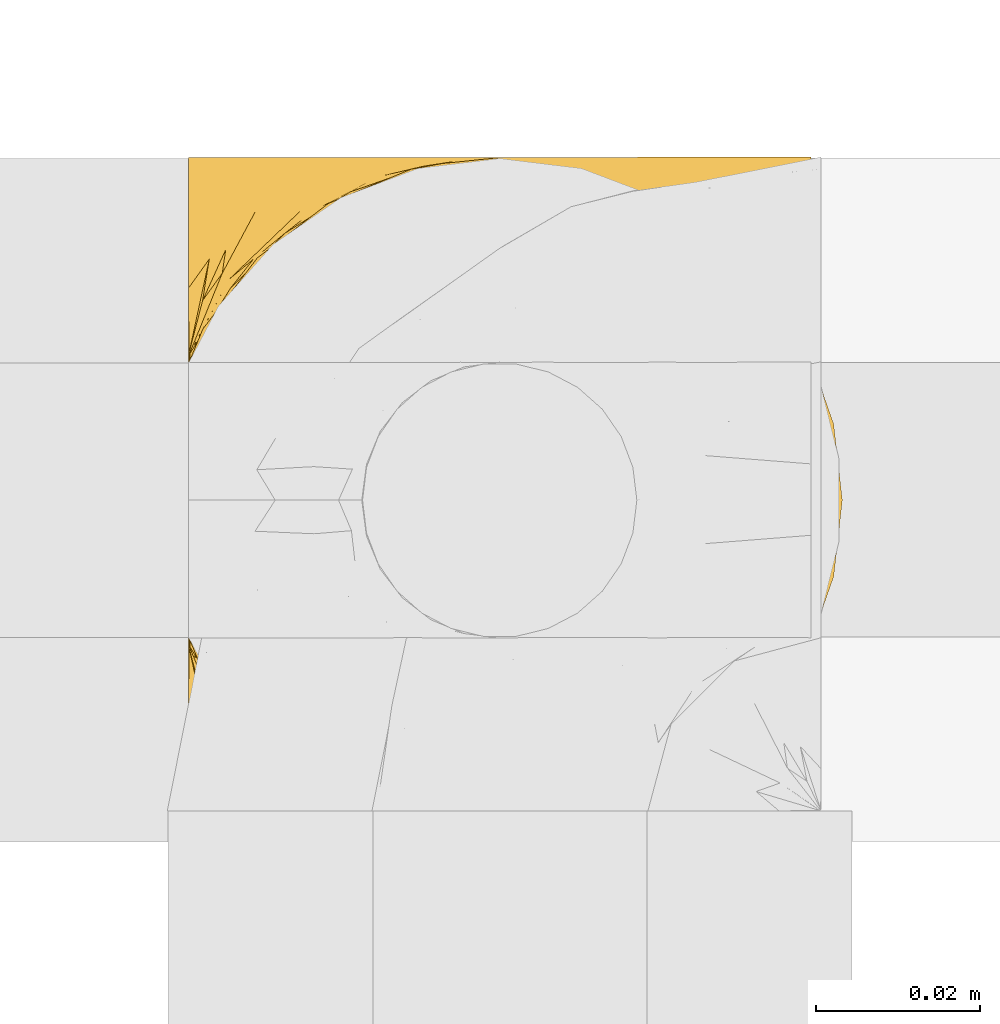
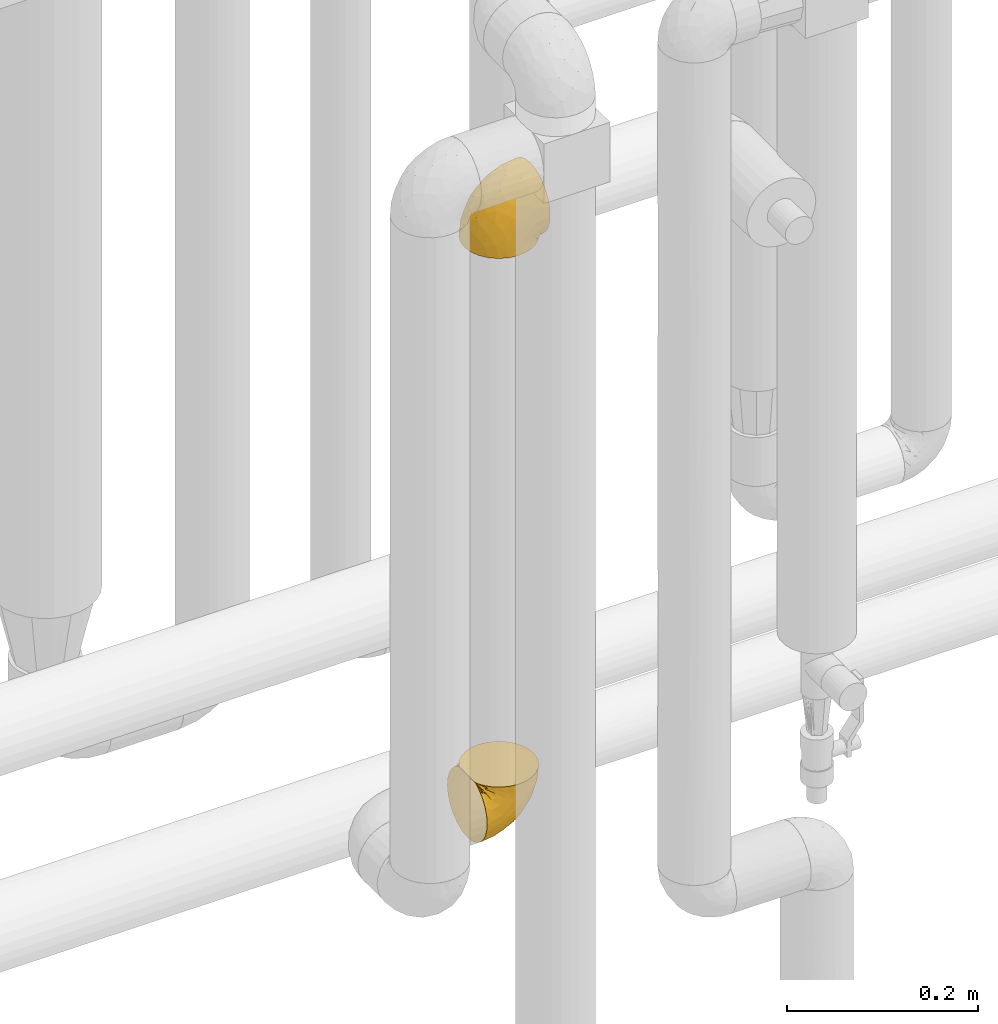
# One storey, part 446 of 827: 2 coverings.
"""IFC2X3 building model written with IfcOpenShell, lengths in millimetres."""

import ifcopenshell
import ifcopenshell.guid

model = None  # the IFC model being written
_history = None  # IfcOwnerHistory: only IFC2X3 demands one
_inside = {}  # id of a spatial element -> (the spatial element, [elements in it])
_under = {}  # id of a project, library or spatial element -> (it, [spatial elements below it])
_declared = {}  # id of a project -> (the project, [libraries it declares])
_typed = {}  # id of a type object -> (the type object, [elements of that type])
_made_of = {}  # id of a material, layer set ... -> (it, [elements and type objects made of it])


def new_model(schema):
    """Start an empty IFC model of exactly this schema.

    Asked for "IFC4X3", IfcOpenShell would pick the latest addendum, in which some entities
    have other attributes; the version numbers below select the first issue.
    IFC2X3 requires an IfcOwnerHistory on every rooted entity: one is made here for all.
    """
    global model, _history
    if schema == "IFC4X3":
        model = ifcopenshell.file(schema_version=(4, 3, 0, 0))
    else:
        model = ifcopenshell.file(schema=schema)
    _inside.clear()
    _under.clear()
    _declared.clear()
    _typed.clear()
    _made_of.clear()
    _history = None
    if model.schema == "IFC2X3":
        org = make("IfcOrganization", Name="unknown")
        user = make(
            "IfcPersonAndOrganization",
            ThePerson=make("IfcPerson", FamilyName="unknown"),
            TheOrganization=org,
        )
        app = make(
            "IfcApplication",
            ApplicationDeveloper=org,
            Version="unknown",
            ApplicationFullName="unknown",
            ApplicationIdentifier="unknown",
        )
        _history = make(
            "IfcOwnerHistory",
            OwningUser=user,
            OwningApplication=app,
            ChangeAction="ADDED",
            CreationDate=0,
        )
    return model


def make(cls, **values):
    """One entity of the class cls with the attributes given. An attribute that is None is left unset."""
    return model.create_entity(
        cls, **{name: value for name, value in values.items() if value is not None}
    )


def entity(cls, *values):
    """Any entity or typed value of the class cls, its attributes in the order of the schema. None: left unset."""
    e = model.create_entity(cls)
    for i, value in enumerate(values):
        if value is not None:
            e[i] = value
    return e


def rooted(cls, **values):
    """An entity with a GlobalId (a new one), such as an element, a storey or a relation."""
    return make(cls, GlobalId=ifcopenshell.guid.new(), OwnerHistory=_history, **values)


def si_unit(unit_type, name, prefix=None):
    """IfcSIUnit, for example si_unit("LENGTHUNIT", "METRE", prefix="MILLI")."""
    return make("IfcSIUnit", UnitType=unit_type, Prefix=prefix, Name=name)


def converted_unit(unit_type, name, factor, base, dimensions=None, offset=None):
    """IfcConversionBasedUnit, such as the inch: factor (a typed value) times the base unit."""
    return make(
        "IfcConversionBasedUnit"
        if offset is None
        else "IfcConversionBasedUnitWithOffset",
        ConversionOffset=offset,
        Dimensions=None
        if dimensions is None
        else entity("IfcDimensionalExponents", *dimensions),
        UnitType=unit_type,
        Name=name,
        ConversionFactor=make(
            "IfcMeasureWithUnit", ValueComponent=factor, UnitComponent=base
        ),
    )


def derived_unit(unit_type, elements):
    """IfcDerivedUnit: a product of units, each with its exponent."""
    return make(
        "IfcDerivedUnit",
        Elements=[
            make("IfcDerivedUnitElement", Unit=unit, Exponent=power)
            for unit, power in elements
        ],
        UnitType=unit_type,
    )


def assignment(units):
    """IfcUnitAssignment: the units of a project."""
    return None if units is None else make("IfcUnitAssignment", Units=units)


def point(xyz):
    """IfcCartesianPoint."""
    return None if xyz is None else make("IfcCartesianPoint", Coordinates=xyz)


def direction(xyz):
    """IfcDirection."""
    return None if xyz is None else make("IfcDirection", DirectionRatios=xyz)


def frame(location, z_axis=None, x_axis=None):
    """IfcAxis2Placement3D, a coordinate frame: its origin and axes. An axis left out is left unset."""
    return make(
        "IfcAxis2Placement3D",
        Location=point(location),
        Axis=direction(z_axis),
        RefDirection=direction(x_axis),
    )


def origin():
    """The frame at (0, 0, 0) with its axes left unset."""
    return frame((0.0, 0.0, 0.0))


def place(relative_to, where):
    """IfcLocalPlacement: puts the frame where relative to a parent placement (None: the world)."""
    return make(
        "IfcLocalPlacement", PlacementRelTo=relative_to, RelativePlacement=where
    )


def context(
    kind, dimensions, precision=None, world=None, true_north=None, identifier=None
):
    """IfcGeometricRepresentationContext, for example the 3D "Model" context."""
    return make(
        "IfcGeometricRepresentationContext",
        ContextIdentifier=identifier,
        ContextType=kind,
        CoordinateSpaceDimension=dimensions,
        Precision=precision,
        WorldCoordinateSystem=world,
        TrueNorth=true_north,
    )


def subcontext(parent, identifier, kind, view, scale=None):
    """IfcGeometricRepresentationSubContext, for example "Body" below "Model"."""
    return make(
        "IfcGeometricRepresentationSubContext",
        ContextIdentifier=identifier,
        ContextType=kind,
        ParentContext=parent,
        TargetScale=scale,
        TargetView=view,
    )


def project(units=None, contexts=None):
    """IfcProject with its units and contexts."""
    return rooted(
        "IfcProject",
        Name="project",
        RepresentationContexts=contexts,
        UnitsInContext=assignment(units),
    )


def spatial(cls, under=None, at=None, **own):
    """A site, building, storey or space (cls), placed at a placement, below another one or the project."""
    s = rooted(cls, ObjectPlacement=at, **own)
    if under is not None:
        _under.setdefault(under.id(), (under, []))[1].append(s)
    return s


def faces_of(points, faces, orient=None, outer=None):
    """IfcFace entities. A face is a list of loops; a loop is a list of indices into points, from 0.

    orient and outer hold one flag for each loop. By default every Orientation is true, the
    first loop of a face is its IfcFaceOuterBound and the others are IfcFaceBound.
    """
    made = []
    for i, loops in enumerate(faces):
        bounds = []
        for j, loop in enumerate(loops):
            is_outer = j == 0 if outer is None else outer[i][j]
            bounds.append(
                make(
                    "IfcFaceOuterBound" if is_outer else "IfcFaceBound",
                    Bound=make("IfcPolyLoop", Polygon=[points[k] for k in loop]),
                    Orientation=True if orient is None else orient[i][j],
                )
            )
        made.append(make("IfcFace", Bounds=bounds))
    return made


def faceted_brep(points, faces, orient=None, outer=None, voids=None):
    """IfcFacetedBrep: a solid bounded by flat faces; with voids (closed shells), ...WithVoids."""
    shared = [point(p) for p in points]
    hull = make("IfcClosedShell", CfsFaces=faces_of(shared, faces, orient, outer))
    if voids is None:
        return make("IfcFacetedBrep", Outer=hull)
    return make(
        "IfcFacetedBrepWithVoids",
        Outer=hull,
        Voids=[
            make(cls, CfsFaces=faces_of(shared, fs, o, b)) for cls, fs, o, b in voids
        ],
    )


def shape(context_of_items, identifier, shape_type, items):
    """IfcShapeRepresentation: the items that make up one representation, for example the "Body"."""
    return make(
        "IfcShapeRepresentation",
        ContextOfItems=context_of_items,
        RepresentationIdentifier=identifier,
        RepresentationType=shape_type,
        Items=items,
    )


def made_of(thing, what):
    """Note that an element or type object is made of a material, layer set ...; save() writes the relation."""
    if what is not None:
        _made_of.setdefault(what.id(), (what, []))[1].append(thing)
    return thing


def element(
    cls,
    number,
    at=None,
    inside=None,
    cuts=None,
    type_object=None,
    material=None,
    context=None,
    identifier="Body",
    shape_type=None,
    held_by="IfcProductDefinitionShape",
    body=None,
    shapes=None,
    **own,
):
    """One element of the class cls, such as IfcWall. Its Tag is "e" and its number.

    at: its placement. inside: the storey or other place that contains it. cuts: it is an
    opening in that element (IfcRelVoidsElement). A single representation is given by context,
    identifier, shape_type and body (its items); several are given by shapes. held_by: the class
    of the entity that holds the representations. save() writes the other relations.
    """
    e = rooted(cls, Tag="e%d" % number, ObjectPlacement=at, **own)
    if body is not None:
        shapes = [shape(context, identifier, shape_type, body)]
    if shapes is not None:
        e.Representation = make(held_by, Representations=shapes)
    if inside is not None:
        _inside.setdefault(inside.id(), (inside, []))[1].append(e)
    if cuts is not None:
        rooted(
            "IfcRelVoidsElement", RelatingBuildingElement=cuts, RelatedOpeningElement=e
        )
    if type_object is not None:
        _typed.setdefault(type_object.id(), (type_object, []))[1].append(e)
    return made_of(e, material)


def aggregate(whole, parts):
    """IfcRelAggregates: a whole, such as a stair, and the parts it consists of."""
    return rooted("IfcRelAggregates", RelatingObject=whole, RelatedObjects=parts)


def save(model, path):
    """Write the relations noted so far, then the file.

    IfcRelAggregates (storeys below a building ...), IfcRelContainedInSpatialStructure (elements
    in a storey), IfcRelDefinesByType, IfcRelAssociatesMaterial and IfcRelDeclares: one each for
    every whole, place, type object, material and project.
    """
    for whole, parts in _under.values():
        aggregate(whole, parts)
    for where, things in _inside.values():
        rooted(
            "IfcRelContainedInSpatialStructure",
            RelatedElements=things,
            RelatingStructure=where,
        )
    for kind, things in _typed.values():
        rooted("IfcRelDefinesByType", RelatedObjects=things, RelatingType=kind)
    for what, things in _made_of.values():
        rooted("IfcRelAssociatesMaterial", RelatedObjects=things, RelatingMaterial=what)
    for by, libraries in _declared.values():
        rooted("IfcRelDeclares", RelatingContext=by, RelatedDefinitions=libraries)
    model.write(path)


model = new_model("IFC2X3")

# Units and contexts
model_context = context("Model", 3, precision=0.01, world=origin(), true_north=direction((6.12303176911189e-17, 1.0)))
body_context = subcontext(model_context, "Body", "Model", "MODEL_VIEW")
ifc_project = project(units=[si_unit("LENGTHUNIT", "METRE", prefix="MILLI"), si_unit("AREAUNIT", "SQUARE_METRE"), si_unit("VOLUMEUNIT", "CUBIC_METRE"), converted_unit("PLANEANGLEUNIT", "DEGREE", entity("IfcRatioMeasure", 0.0174532925199433), si_unit("PLANEANGLEUNIT", "RADIAN"), dimensions=[0, 0, 0, 0, 0, 0, 0]), si_unit("MASSUNIT", "GRAM", prefix="KILO"), derived_unit("MASSDENSITYUNIT", [(si_unit("MASSUNIT", "GRAM", prefix="KILO"), 1), (si_unit("LENGTHUNIT", "METRE"), -3)]), derived_unit("MOMENTOFINERTIAUNIT", [(si_unit("LENGTHUNIT", "METRE"), 4)]), si_unit("TIMEUNIT", "SECOND"), si_unit("FREQUENCYUNIT", "HERTZ"), si_unit("THERMODYNAMICTEMPERATUREUNIT", "DEGREE_CELSIUS"), derived_unit("THERMALTRANSMITTANCEUNIT", [(si_unit("MASSUNIT", "GRAM", prefix="KILO"), 1), (si_unit("THERMODYNAMICTEMPERATUREUNIT", "KELVIN"), -1), (si_unit("TIMEUNIT", "SECOND"), -3)]), derived_unit("VOLUMETRICFLOWRATEUNIT", [(si_unit("LENGTHUNIT", "METRE"), 3), (si_unit("TIMEUNIT", "SECOND"), -1)]), derived_unit("MASSFLOWRATEUNIT", [(si_unit("MASSUNIT", "GRAM", prefix="KILO"), 1), (si_unit("TIMEUNIT", "SECOND"), -1)]), derived_unit("ROTATIONALFREQUENCYUNIT", [(si_unit("TIMEUNIT", "SECOND"), -1)]), si_unit("ELECTRICCURRENTUNIT", "AMPERE"), si_unit("ELECTRICVOLTAGEUNIT", "VOLT"), si_unit("POWERUNIT", "WATT"), si_unit("FORCEUNIT", "NEWTON", prefix="KILO"), si_unit("ILLUMINANCEUNIT", "LUX"), si_unit("LUMINOUSFLUXUNIT", "LUMEN"), si_unit("LUMINOUSINTENSITYUNIT", "CANDELA"), derived_unit("USERDEFINED", [(si_unit("MASSUNIT", "GRAM", prefix="KILO"), -1), (si_unit("LENGTHUNIT", "METRE"), -2), (si_unit("TIMEUNIT", "SECOND"), 3), (si_unit("LUMINOUSFLUXUNIT", "LUMEN"), 1)]), derived_unit("LINEARVELOCITYUNIT", [(si_unit("LENGTHUNIT", "METRE"), 1), (si_unit("TIMEUNIT", "SECOND"), -1)]), si_unit("PRESSUREUNIT", "PASCAL"), derived_unit("USERDEFINED", [(si_unit("LENGTHUNIT", "METRE"), -2), (si_unit("MASSUNIT", "GRAM", prefix="KILO"), 1), (si_unit("TIMEUNIT", "SECOND"), -2)]), derived_unit("LINEARFORCEUNIT", [(si_unit("MASSUNIT", "GRAM", prefix="KILO"), 1), (si_unit("LENGTHUNIT", "METRE"), 1), (si_unit("TIMEUNIT", "SECOND"), -2), (si_unit("LENGTHUNIT", "METRE"), -1)]), derived_unit("PLANARFORCEUNIT", [(si_unit("MASSUNIT", "GRAM", prefix="KILO"), 1), (si_unit("LENGTHUNIT", "METRE"), 1), (si_unit("TIMEUNIT", "SECOND"), -2), (si_unit("LENGTHUNIT", "METRE"), -2)])], contexts=[model_context])

# Site, building, storey
site_placement = place(None, origin())
site = spatial("IfcSite", under=ifc_project, at=site_placement, CompositionType="ELEMENT")
building_placement = place(site_placement, origin())
building = spatial("IfcBuilding", under=site, at=building_placement, CompositionType="ELEMENT")
storey_placement = place(building_placement, frame((0.0, 0.0, 28200.0)))
storey = spatial("IfcBuildingStorey", under=building, at=storey_placement, Name="08", CompositionType="ELEMENT", Elevation=28200.0)

# Coverings
covering_1_placement = place(storey_placement, frame((58984.29, 15517.02, 1657.08)))
element("IfcCovering", 1, at=covering_1_placement, inside=storey, Name=":ADSK_", ObjectType=":ADSK_", PredefinedType="INSULATION", context=body_context, shape_type="Brep", body=[
    faceted_brep([(57.76, 5.74, 81.45), (65.69, 10.73, 81.45), (72.32, 17.36, 81.45), (77.3, 25.29, 81.45), (80.4, 34.14, 81.45), (81.45, 43.45, 81.45), (80.39, 52.76, 81.45), (77.3, 61.61, 81.45), (72.31, 69.54, 81.45), (65.68, 76.17, 81.45), (57.75, 81.15, 81.45), (48.9, 84.25, 81.45), (39.6, 85.3, 81.45), (30.22, 84.23, 81.45), (21.33, 81.1, 81.45), (13.37, 76.06, 81.45), (6.73, 69.36, 81.45), (1.77, 61.36, 81.45), (1.77, 60.44, 81.45), (1.77, 59.52, 81.45), (1.77, 58.72, 81.45), (1.77, 57.4, 81.45), (1.77, 56.08, 81.45), (1.77, 54.76, 81.45), (1.77, 53.44, 81.45), (1.77, 52.12, 81.45), (1.77, 50.8, 81.45), (1.77, 49.47, 81.45), (1.77, 48.15, 81.45), (1.77, 46.83, 81.45), (1.77, 45.51, 81.45), (1.77, 44.19, 81.45), (1.77, 42.87, 81.45), (1.77, 41.55, 81.45), (1.77, 40.23, 81.45), (1.77, 39.31, 81.45), (1.77, 38.39, 81.45), (1.77, 37.48, 81.45), (1.77, 36.56, 81.45), (1.77, 35.64, 81.45), (1.77, 34.72, 81.45), (1.77, 33.8, 81.45), (1.77, 32.88, 81.45), (1.77, 31.96, 81.45), (1.77, 31.05, 81.45), (1.77, 30.13, 81.45), (1.77, 29.21, 81.45), (1.77, 28.29, 81.45), (1.77, 27.37, 81.45), (1.77, 26.45, 81.45), (1.77, 25.53, 81.45), (6.74, 17.52, 81.45), (13.38, 10.82, 81.45), (21.35, 5.78, 81.45), (30.24, 2.65, 81.45), (39.6, 1.6, 81.45), (48.91, 2.65, 81.45), (1.6, 69.37, 76.3), (1.6, 76.06, 69.67), (1.6, 81.1, 61.7), (1.6, 84.23, 52.81), (1.6, 85.3, 43.45), (1.6, 83.87, 32.61), (1.6, 79.69, 22.52), (1.6, 73.04, 13.85), (1.6, 64.37, 7.2), (1.6, 54.28, 3.02), (1.6, 43.45, 1.6), (1.6, 32.61, 3.02), (1.6, 22.52, 7.2), (1.6, 13.85, 13.85), (1.6, 7.2, 22.52), (1.6, 3.02, 32.61), (1.6, 1.6, 43.45), (1.6, 2.66, 52.81), (1.6, 5.79, 61.7), (1.6, 10.83, 69.67), (1.6, 17.52, 76.3), (1.6, 25.53, 81.27), (1.6, 26.45, 81.27), (1.6, 27.77, 81.27), (1.6, 28.89, 81.27), (1.6, 30.01, 81.27), (1.6, 31.13, 81.27), (1.6, 32.25, 81.27), (1.6, 33.37, 81.27), (1.6, 34.49, 81.27), (1.6, 35.61, 81.27), (1.6, 36.73, 81.27), (1.6, 37.85, 81.27), (1.6, 38.97, 81.27), (1.6, 40.09, 81.27), (1.6, 41.21, 81.27), (1.6, 42.33, 81.27), (1.6, 43.45, 81.27), (1.6, 44.77, 81.27), (1.6, 46.09, 81.27), (1.6, 47.41, 81.27), (1.6, 48.73, 81.27), (1.6, 50.05, 81.27), (1.6, 51.37, 81.27), (1.6, 52.69, 81.27), (1.6, 54.01, 81.27), (1.6, 54.93, 81.27), (1.6, 55.85, 81.27), (1.6, 56.76, 81.27), (1.6, 57.68, 81.27), (1.6, 58.6, 81.27), (1.6, 59.52, 81.27), (1.6, 60.44, 81.27), (1.6, 61.36, 81.27), (1.71, 32.81, 81.31), (1.73, 31.73, 81.33), (1.71, 50.71, 81.31), (1.72, 51.76, 81.32), (1.71, 42.89, 81.31), (1.72, 41.81, 81.32), (1.72, 25.53, 81.32), (1.72, 26.91, 81.32), (1.72, 40.71, 81.32), (1.72, 60.15, 81.32), (1.72, 39.53, 81.32), (1.72, 57.22, 81.32), (1.7, 58.17, 81.3), (1.72, 47.12, 81.32), (1.73, 33.93, 81.33), (1.72, 35.05, 81.31), (1.73, 46.09, 81.33), (1.73, 45.02, 81.32), (1.72, 43.95, 81.32), (1.72, 59.12, 81.32), (1.71, 38.49, 81.31), (1.72, 49.68, 81.32), (1.71, 53.35, 81.31), (1.72, 54.4, 81.32), (1.72, 56.2, 81.32), (1.72, 36.2, 81.32), (1.73, 37.29, 81.33), (1.72, 30.57, 81.32), (1.71, 29.45, 81.31), (1.73, 28.01, 81.33), (1.72, 61.36, 81.32), (1.74, 25.53, 81.36), (1.75, 25.53, 81.4), (1.75, 61.36, 81.4), (1.74, 61.36, 81.36), (1.64, 25.53, 81.29), (1.68, 61.36, 81.3), (1.64, 61.36, 81.29), (1.74, 55.3, 81.35), (1.71, 48.18, 81.31), (8.98, 82.92, 58.5), (37.05, 85.3, 71.95), (24.69, 82.92, 74.57), (15.28, 78.8, 73.93), (16.86, 78.8, 78.18), (6.58, 70.46, 78.04), (5.71, 71.16, 76.23), (11.1, 85.3, 45.99), (10.79, 76.1, 74.01), (4.13, 72.9, 73.57), (6.62, 78.81, 66.66), (9.52, 72.89, 79.09), (6.14, 74.06, 73.14), (17.79, 83.71, 60.34), (20.6, 85.3, 48.54), (8.73, 85.3, 45.36), (23.66, 83.61, 67.22), (34.5, 85.3, 62.45), (15.32, 80.61, 68.67), (27.55, 85.3, 55.49), (3.31, 67.83, 77.84), (9.81, 78.81, 68.16), (37.68, 85.3, 74.31), (67.23, 54.78, 38.78), (76.64, 57.27, 62.1), (75.37, 43.45, 50.89), (14.58, 84.45, 36.91), (23.71, 84.39, 40.37), (34.34, 77.16, 27.86), (29.1, 68.92, 15.77), (18.02, 76.65, 20.13), (22.27, 82.11, 31.54), (10.97, 82.11, 28.25), (56.79, 78.88, 57.26), (60.76, 78.88, 69.99), (67.04, 73.04, 64.58), (36.11, 84.47, 50.64), (68.85, 65.72, 51.97), (24.58, 51.16, 5.72), (21.54, 59.46, 7.42), (78.4, 43.45, 66.14), (14.11, 68.92, 11.35), (53.42, 51.18, 21.64), (58.19, 57.42, 28.57), (44.49, 83.48, 55.38), (51.77, 82.95, 68.51), (73.69, 65.72, 67.48), (45.89, 78.97, 40.78), (35.97, 82.64, 41.53), (56.55, 75.14, 46.11), (60.03, 68.58, 40.32), (63.64, 61.95, 38.36), (34.98, 58.11, 11.84), (40.58, 51.07, 12.56), (32.15, 43.45, 7.67), (47.26, 58.51, 19.39), (58.06, 43.45, 24.98), (66.71, 43.45, 37.94), (16.9, 43.45, 4.64), (52.08, 65.68, 28.09), (41.21, 70.41, 23.73), (49.76, 73.04, 34.03), (45.11, 43.45, 16.33), (15.65, 4.78, 29.29), (24.57, 35.48, 5.77), (50.54, 29.45, 21.44), (67.25, 32.11, 38.8), (67.06, 13.86, 64.58), (73.7, 21.19, 67.49), (26.13, 10.24, 22.9), (19.54, 17.97, 12.54), (38.96, 18.88, 20.04), (56.8, 8.01, 57.26), (60.77, 8.01, 69.99), (51.78, 3.95, 68.51), (59.09, 22.45, 34.54), (19.25, 2.4, 38.81), (20.6, 1.6, 48.54), (11.1, 1.6, 45.99), (37.68, 1.6, 74.31), (15.21, 29.05, 5.36), (12.76, 10.24, 18.96), (40.93, 35.7, 12.79), (76.65, 29.63, 62.11), (39.5, 8.75, 33.14), (25.01, 4.54, 33.44), (68.86, 21.19, 51.98), (26.7, 2.28, 43.42), (34.95, 2.53, 48.62), (34.5, 1.6, 62.45), (27.55, 1.6, 55.49), (61.27, 13.86, 49.68), (44.5, 3.41, 55.37), (37.05, 1.6, 71.95), (10.25, 2.35, 36.37), (49.78, 13.86, 34.04), (47.51, 7.35, 44.1), (29.38, 27.43, 9.99), (40.01, 13.39, 26.41), (33.36, 4.32, 39.19), (8.98, 3.97, 58.5), (23.67, 3.27, 67.22), (24.71, 3.97, 74.57), (15.29, 8.08, 73.92), (4.13, 13.99, 73.57), (6.14, 12.83, 73.14), (4.96, 8.08, 66.19), (9.81, 8.08, 68.16), (3.31, 19.06, 77.84), (5.7, 15.74, 76.23), (1.68, 25.53, 81.3), (9.53, 13.98, 79.08), (6.59, 16.42, 78.04), (16.63, 8.08, 77.18), (15.34, 6.27, 68.66), (10.8, 10.78, 74.0), (17.79, 3.18, 60.34)], [[[0, 1, 2, 3, 4, 5, 6, 7, 8, 9, 10, 11, 12, 13, 14, 15, 16, 17, 18, 19, 20, 21, 22, 23, 24, 25, 26, 27, 28, 29, 30, 31, 32, 33, 34, 35, 36, 37, 38, 39, 40, 41, 42, 43, 44, 45, 46, 47, 48, 49, 50, 51, 52, 53, 54, 55, 56]], [[57, 58, 59, 60, 61, 62, 63, 64, 65, 66, 67, 68, 69, 70, 71, 72, 73, 74, 75, 76, 77, 78, 79, 80, 81, 82, 83, 84, 85, 86, 87, 88, 89, 90, 91, 92, 93, 94, 95, 96, 97, 98, 99, 100, 101, 102, 103, 104, 105, 106, 107, 108, 109, 110]], [[111, 84, 112]], [[113, 26, 114]], [[114, 101, 100]], [[115, 93, 116]], [[79, 117, 118]], [[33, 116, 119]], [[117, 49, 118]], [[19, 18, 120]], [[119, 121, 34]], [[122, 21, 123]], [[97, 96, 124]], [[86, 125, 126]], [[116, 92, 119]], [[127, 96, 128]], [[32, 129, 115]], [[19, 120, 130]], [[121, 90, 131]], [[94, 115, 129]], [[115, 116, 32]], [[118, 49, 48]], [[113, 99, 132]], [[133, 114, 25]], [[24, 134, 133]], [[135, 22, 122]], [[136, 137, 88]], [[84, 83, 112]], [[138, 82, 139]], [[130, 20, 19]], [[118, 48, 140]], [[81, 140, 139]], [[123, 21, 20]], [[141, 120, 18]], [[139, 82, 81]], [[130, 107, 123]], [[49, 117, 142, 143, 50]], [[18, 17, 144, 145, 141]], [[79, 78, 146]], [[109, 141, 147]], [[109, 148, 110]], [[102, 133, 134]], [[105, 135, 122]], [[118, 80, 79]], [[80, 118, 140]], [[120, 109, 108]], [[47, 46, 140, 48]], [[81, 80, 140]], [[44, 112, 138]], [[93, 115, 94]], [[46, 139, 140]], [[46, 45, 139]], [[139, 45, 138]], [[138, 112, 83]], [[85, 84, 111]], [[112, 43, 111]], [[83, 82, 138]], [[106, 122, 123]], [[105, 122, 106]], [[21, 122, 22]], [[124, 29, 28]], [[33, 32, 116]], [[128, 129, 31]], [[32, 31, 129]], [[34, 33, 119]], [[116, 93, 92]], [[129, 95, 94]], [[95, 129, 128]], [[41, 40, 125, 42]], [[119, 91, 121]], [[36, 35, 131, 37]], [[137, 131, 89]], [[121, 131, 35]], [[90, 121, 91]], [[119, 92, 91]], [[136, 126, 39]], [[125, 86, 85]], [[42, 125, 111]], [[85, 111, 125]], [[149, 23, 22]], [[130, 108, 107]], [[130, 123, 20]], [[107, 106, 123]], [[137, 37, 131]], [[136, 38, 137]], [[89, 88, 137]], [[131, 90, 89]], [[124, 150, 97]], [[40, 39, 126]], [[87, 126, 136]], [[86, 126, 87]], [[136, 88, 87]], [[40, 126, 125]], [[39, 38, 136]], [[95, 128, 96]], [[30, 128, 31]], [[29, 124, 127]], [[127, 128, 30]], [[150, 124, 28]], [[127, 30, 29]], [[127, 124, 96]], [[150, 98, 97]], [[45, 44, 138]], [[26, 113, 132]], [[113, 100, 99]], [[132, 150, 27]], [[27, 26, 132]], [[26, 25, 114]], [[100, 113, 114]], [[101, 133, 102]], [[133, 101, 114]], [[28, 27, 150]], [[132, 99, 98]], [[23, 134, 24]], [[25, 24, 133]], [[134, 23, 149]], [[135, 104, 149]], [[149, 104, 103]], [[103, 102, 134]], [[130, 120, 108]], [[109, 120, 141]], [[42, 111, 43]], [[112, 44, 43]], [[104, 135, 105]], [[134, 149, 103]], [[135, 149, 22]], [[35, 34, 121]], [[137, 38, 37]], [[98, 150, 132]], [[59, 151, 60]], [[13, 152, 153]], [[154, 155, 153]], [[156, 157, 141]], [[158, 60, 151]], [[159, 156, 154]], [[160, 161, 58]], [[58, 161, 59]], [[144, 16, 162]], [[58, 57, 160]], [[161, 160, 163]], [[156, 162, 154]], [[162, 16, 15]], [[57, 148, 160]], [[151, 164, 165]], [[156, 144, 162]], [[60, 158, 166, 61]], [[155, 14, 153]], [[162, 155, 154]], [[154, 153, 167]], [[167, 153, 168]], [[154, 169, 159]], [[57, 110, 148]], [[144, 17, 16]], [[155, 15, 14]], [[170, 164, 167]], [[157, 163, 171]], [[14, 13, 153]], [[156, 141, 145, 144]], [[172, 163, 157]], [[172, 159, 169]], [[170, 165, 164]], [[167, 164, 169]], [[167, 168, 170]], [[151, 172, 164]], [[169, 154, 167]], [[164, 172, 169]], [[159, 172, 157]], [[171, 148, 147]], [[147, 141, 157]], [[157, 156, 159]], [[151, 165, 158]], [[172, 151, 161]], [[59, 161, 151]], [[13, 12, 173, 152]], [[152, 168, 153]], [[15, 155, 162]], [[161, 163, 172]], [[171, 163, 160]], [[148, 171, 160]], [[157, 171, 147]], [[174, 175, 176]], [[177, 165, 178]], [[179, 180, 181]], [[182, 183, 177]], [[184, 185, 186]], [[170, 187, 178]], [[173, 12, 11]], [[188, 175, 174]], [[189, 66, 190]], [[175, 6, 191]], [[192, 65, 64]], [[63, 183, 181]], [[63, 181, 64]], [[65, 192, 190]], [[183, 63, 62]], [[174, 193, 194]], [[195, 168, 196]], [[173, 11, 196]], [[8, 7, 197]], [[186, 9, 8]], [[196, 168, 152, 173]], [[196, 11, 10]], [[185, 196, 10]], [[198, 179, 199]], [[196, 184, 195]], [[200, 188, 201]], [[200, 186, 188]], [[194, 202, 174]], [[190, 203, 189]], [[175, 7, 6]], [[176, 175, 191]], [[188, 197, 175]], [[65, 190, 66]], [[197, 186, 8]], [[204, 205, 189]], [[9, 185, 10]], [[180, 206, 203]], [[207, 174, 176, 208]], [[66, 189, 209]], [[210, 211, 212]], [[189, 203, 204]], [[179, 181, 182]], [[192, 181, 180]], [[62, 61, 166]], [[195, 184, 198]], [[195, 199, 187]], [[6, 5, 191]], [[175, 197, 7]], [[186, 197, 188]], [[186, 185, 9]], [[196, 185, 184]], [[199, 179, 182]], [[179, 212, 211]], [[178, 182, 177]], [[184, 200, 198]], [[209, 189, 205]], [[209, 67, 66]], [[204, 203, 206]], [[193, 204, 206]], [[193, 213, 204]], [[194, 193, 206]], [[207, 193, 174]], [[206, 210, 194]], [[201, 202, 210]], [[211, 206, 180]], [[201, 210, 212]], [[200, 201, 212]], [[188, 174, 202]], [[198, 200, 212]], [[186, 200, 184]], [[179, 198, 212]], [[195, 198, 199]], [[210, 202, 194]], [[188, 202, 201]], [[206, 211, 210]], [[179, 211, 180]], [[213, 193, 207]], [[213, 205, 204]], [[195, 187, 168]], [[180, 203, 190]], [[181, 192, 64]], [[190, 192, 180]], [[177, 62, 166]], [[181, 183, 182]], [[62, 177, 183]], [[177, 166, 158, 165]], [[170, 178, 165]], [[199, 182, 178]], [[178, 187, 199]], [[168, 187, 170]], [[71, 214, 72]], [[205, 215, 209]], [[216, 207, 217]], [[215, 68, 209]], [[218, 219, 2]], [[220, 221, 222]], [[223, 224, 225]], [[226, 222, 216]], [[227, 228, 229]], [[56, 230, 225]], [[231, 221, 69]], [[56, 55, 230]], [[70, 232, 71]], [[71, 232, 214]], [[0, 56, 225]], [[207, 216, 233]], [[217, 176, 234]], [[220, 235, 236]], [[237, 219, 218]], [[1, 218, 2]], [[68, 215, 231]], [[234, 3, 219]], [[234, 191, 4]], [[1, 0, 224]], [[227, 238, 228]], [[239, 240, 241]], [[242, 237, 218]], [[223, 225, 243]], [[225, 240, 243]], [[3, 234, 4]], [[69, 221, 70]], [[224, 218, 1]], [[217, 234, 237]], [[242, 218, 223]], [[217, 226, 216]], [[3, 2, 219]], [[217, 207, 208, 176]], [[225, 230, 244, 240]], [[214, 227, 245]], [[246, 247, 235]], [[247, 223, 243]], [[222, 221, 248]], [[232, 221, 220]], [[241, 238, 239]], [[247, 246, 242]], [[216, 222, 248]], [[249, 246, 235]], [[215, 233, 248]], [[217, 237, 226]], [[191, 234, 176]], [[191, 5, 4]], [[72, 245, 73]], [[234, 219, 237]], [[225, 224, 0]], [[218, 224, 223]], [[239, 247, 243]], [[238, 241, 228]], [[235, 247, 250]], [[68, 67, 209]], [[233, 215, 205]], [[215, 248, 231]], [[233, 205, 213, 207]], [[248, 233, 216]], [[221, 231, 248]], [[69, 68, 231]], [[245, 227, 229]], [[236, 227, 214]], [[242, 226, 237]], [[222, 226, 246]], [[73, 245, 229]], [[214, 245, 72]], [[247, 242, 223]], [[226, 242, 246]], [[236, 235, 250]], [[249, 220, 222]], [[221, 232, 70]], [[214, 232, 220]], [[220, 236, 214]], [[238, 236, 250]], [[236, 238, 227]], [[238, 250, 239]], [[247, 239, 250]], [[240, 239, 243]], [[220, 249, 235]], [[222, 246, 249]], [[74, 229, 251]], [[252, 253, 254]], [[146, 77, 255]], [[256, 257, 258]], [[259, 255, 256]], [[259, 260, 261]], [[75, 74, 251]], [[51, 143, 262]], [[263, 143, 142, 117]], [[255, 77, 76]], [[251, 257, 75]], [[252, 240, 253]], [[253, 244, 54]], [[257, 255, 76]], [[53, 52, 264]], [[254, 265, 252]], [[253, 264, 254]], [[254, 264, 262]], [[75, 257, 76]], [[265, 254, 266]], [[254, 262, 263]], [[51, 50, 143]], [[54, 244, 230, 55]], [[51, 262, 52]], [[252, 267, 241]], [[253, 54, 53]], [[266, 258, 265]], [[146, 78, 77]], [[263, 117, 260]], [[146, 255, 259]], [[256, 258, 260]], [[267, 252, 265]], [[228, 267, 251]], [[241, 267, 228]], [[241, 240, 252]], [[251, 267, 258]], [[254, 263, 266]], [[258, 267, 265]], [[260, 117, 261]], [[263, 260, 266]], [[258, 266, 260]], [[229, 74, 73]], [[229, 228, 251]], [[258, 257, 251]], [[253, 240, 244]], [[53, 264, 253]], [[52, 262, 264]], [[143, 263, 262]], [[257, 256, 255]], [[260, 259, 256]], [[146, 259, 261]], [[79, 146, 261, 117]], [[109, 147, 148]]]),
])
covering_2_placement = place(storey_placement, frame((58980.44, 15517.02, 2410.87)))
element("IfcCovering", 2, at=covering_2_placement, inside=storey, Name=":ADSK_", ObjectType=":ADSK_", PredefinedType="INSULATION", context=body_context, shape_type="Brep", body=[
    faceted_brep([(81.45, 81.23, 57.77), (81.45, 76.25, 65.71), (81.45, 69.63, 72.34), (81.45, 61.71, 77.34), (81.45, 52.87, 80.44), (81.45, 43.56, 81.51), (81.45, 34.24, 80.47), (81.45, 25.39, 77.38), (81.45, 17.45, 72.41), (81.45, 10.81, 65.79), (81.45, 5.82, 57.86), (81.45, 2.71, 49.02), (81.45, 1.65, 39.72), (81.45, 2.7, 30.34), (81.45, 5.82, 21.45), (81.45, 10.85, 13.47), (81.45, 17.54, 6.83), (81.45, 25.53, 1.86), (81.45, 26.45, 1.86), (81.45, 27.37, 1.86), (81.45, 28.17, 1.86), (81.45, 29.49, 1.85), (81.45, 30.81, 1.85), (81.45, 32.13, 1.85), (81.45, 33.45, 1.85), (81.45, 34.78, 1.85), (81.45, 36.1, 1.84), (81.45, 37.42, 1.84), (81.45, 38.74, 1.84), (81.45, 40.06, 1.84), (81.45, 41.38, 1.84), (81.45, 42.7, 1.83), (81.45, 44.02, 1.83), (81.45, 45.34, 1.83), (81.45, 46.66, 1.83), (81.45, 47.58, 1.83), (81.45, 48.5, 1.83), (81.45, 49.41, 1.82), (81.45, 50.33, 1.82), (81.45, 51.25, 1.82), (81.45, 52.17, 1.82), (81.45, 53.09, 1.82), (81.45, 54.01, 1.82), (81.45, 54.93, 1.82), (81.45, 55.85, 1.82), (81.45, 56.76, 1.81), (81.45, 57.68, 1.81), (81.45, 58.6, 1.81), (81.45, 59.52, 1.81), (81.45, 60.44, 1.81), (81.45, 61.36, 1.81), (81.45, 69.38, 6.77), (81.45, 76.09, 13.4), (81.45, 81.14, 21.36), (81.45, 84.28, 30.24), (81.45, 85.35, 39.6), (81.45, 84.31, 48.91), (76.3, 17.52, 1.69), (69.67, 10.83, 1.7), (61.7, 5.79, 1.71), (52.81, 2.66, 1.72), (43.45, 1.6, 1.72), (32.61, 3.02, 1.71), (22.52, 7.2, 1.71), (13.85, 13.85, 1.7), (7.2, 22.52, 1.69), (3.02, 32.61, 1.67), (1.6, 43.45, 1.66), (3.02, 54.28, 1.64), (7.2, 64.37, 1.63), (13.85, 73.04, 1.61), (22.52, 79.69, 1.6), (32.61, 83.87, 1.6), (43.45, 85.3, 1.6), (52.81, 84.23, 1.6), (61.7, 81.1, 1.6), (69.67, 76.06, 1.61), (76.3, 69.37, 1.62), (81.27, 61.36, 1.63), (81.27, 60.44, 1.63), (81.27, 59.12, 1.63), (81.27, 58.0, 1.63), (81.27, 56.88, 1.64), (81.27, 55.76, 1.64), (81.27, 54.64, 1.64), (81.27, 53.52, 1.64), (81.27, 52.4, 1.64), (81.27, 51.28, 1.64), (81.27, 50.16, 1.65), (81.27, 49.04, 1.65), (81.27, 47.92, 1.65), (81.27, 46.8, 1.65), (81.27, 45.68, 1.65), (81.27, 44.56, 1.65), (81.27, 43.45, 1.66), (81.27, 42.12, 1.66), (81.27, 40.8, 1.66), (81.27, 39.48, 1.66), (81.27, 38.16, 1.66), (81.27, 36.84, 1.67), (81.27, 35.52, 1.67), (81.27, 34.2, 1.67), (81.27, 32.88, 1.67), (81.27, 31.96, 1.67), (81.27, 31.05, 1.67), (81.27, 30.13, 1.68), (81.27, 29.21, 1.68), (81.27, 28.29, 1.68), (81.27, 27.37, 1.68), (81.27, 26.45, 1.68), (81.27, 25.53, 1.68), (81.31, 54.08, 1.76), (81.33, 55.16, 1.77), (81.31, 36.18, 1.78), (81.32, 35.13, 1.79), (81.31, 44.01, 1.77), (81.32, 45.08, 1.77), (81.32, 61.36, 1.76), (81.32, 59.98, 1.76), (81.32, 46.18, 1.78), (81.32, 26.74, 1.81), (81.32, 47.36, 1.78), (81.32, 29.67, 1.8), (81.3, 28.72, 1.78), (81.32, 39.77, 1.79), (81.33, 52.96, 1.78), (81.31, 51.84, 1.76), (81.33, 40.8, 1.79), (81.32, 41.87, 1.79), (81.32, 42.94, 1.78), (81.32, 27.77, 1.8), (81.31, 48.4, 1.77), (81.32, 37.21, 1.79), (81.31, 33.54, 1.78), (81.32, 32.49, 1.8), (81.32, 30.69, 1.8), (81.32, 50.69, 1.77), (81.33, 49.6, 1.78), (81.32, 56.32, 1.76), (81.31, 57.44, 1.75), (81.33, 58.88, 1.77), (81.32, 25.53, 1.81), (81.36, 61.36, 1.77), (81.4, 25.53, 1.84), (81.36, 25.53, 1.82), (81.4, 61.36, 1.79), (81.29, 61.36, 1.68), (81.3, 61.36, 1.72), (81.3, 25.53, 1.77), (81.29, 25.53, 1.73), (81.35, 31.59, 1.82), (81.31, 38.71, 1.78), (58.5, 3.98, 9.1), (71.95, 1.65, 37.17), (74.57, 4.01, 24.81), (73.93, 8.11, 15.39), (78.18, 8.11, 16.97), (78.04, 16.44, 6.68), (76.23, 15.74, 5.81), (45.99, 1.61, 11.22), (74.01, 10.81, 10.9), (73.57, 13.99, 4.23), (66.66, 8.09, 6.73), (79.09, 14.01, 9.62), (73.14, 12.83, 6.24), (60.34, 3.2, 17.91), (48.54, 1.62, 20.72), (45.36, 1.61, 8.85), (67.22, 3.31, 23.78), (62.45, 1.64, 34.63), (68.67, 6.3, 15.44), (55.49, 1.63, 27.67), (77.84, 19.06, 3.4), (68.16, 8.09, 9.92), (74.31, 1.65, 37.8), (38.78, 32.2, 67.31), (62.1, 29.73, 76.72), (50.89, 43.55, 75.43), (36.91, 2.46, 14.7), (40.37, 2.53, 23.83), (27.86, 9.78, 34.45), (15.77, 18.01, 29.2), (20.13, 10.27, 18.13), (31.54, 4.81, 22.38), (28.25, 4.79, 11.09), (57.26, 8.09, 56.9), (69.99, 8.09, 60.87), (64.58, 13.94, 67.15), (50.64, 2.47, 36.23), (51.97, 21.27, 68.94), (5.72, 35.76, 24.65), (7.42, 27.46, 21.62), (66.14, 43.56, 78.46), (11.35, 17.99, 14.21), (21.64, 35.79, 53.49), (28.57, 29.55, 58.27), (55.38, 3.47, 44.61), (68.51, 4.01, 51.89), (67.48, 21.28, 73.78), (40.78, 7.99, 46.0), (41.53, 4.3, 36.09), (46.11, 11.83, 56.65), (40.32, 18.39, 60.13), (38.36, 25.03, 63.73), (11.84, 28.83, 35.06), (12.56, 35.88, 40.65), (7.67, 43.49, 32.21), (19.39, 28.44, 47.34), (24.98, 43.53, 58.12), (37.94, 43.54, 66.77), (4.64, 43.47, 16.96), (28.09, 21.28, 52.18), (23.73, 16.54, 41.31), (34.03, 13.92, 49.86), (16.33, 43.51, 45.17), (29.29, 82.13, 15.65), (5.77, 51.44, 24.62), (21.44, 57.52, 50.58), (38.8, 54.87, 67.29), (64.58, 73.13, 67.07), (67.49, 65.81, 73.72), (22.9, 76.68, 26.14), (12.54, 68.95, 19.56), (20.04, 68.06, 38.98), (57.26, 78.96, 56.81), (69.99, 78.96, 60.78), (68.51, 83.02, 51.79), (34.54, 64.53, 59.12), (38.81, 84.52, 19.26), (48.54, 85.32, 20.6), (45.99, 85.31, 11.1), (74.31, 85.35, 37.68), (5.36, 57.86, 15.25), (18.96, 76.66, 12.77), (12.79, 51.25, 40.98), (62.11, 57.37, 76.69), (33.14, 78.2, 39.51), (33.44, 82.39, 25.02), (51.98, 65.8, 68.89), (43.42, 84.64, 26.7), (48.62, 84.41, 34.95), (62.45, 85.34, 34.5), (55.49, 85.33, 27.55), (49.68, 73.12, 61.28), (55.37, 83.54, 44.5), (71.95, 85.35, 37.05), (36.37, 84.56, 10.25), (34.04, 73.1, 49.8), (44.1, 79.6, 47.52), (9.99, 59.5, 29.42), (26.41, 73.56, 40.03), (39.19, 82.61, 33.36), (58.5, 82.93, 8.98), (67.22, 83.65, 23.67), (74.57, 82.96, 24.71), (73.92, 78.83, 15.3), (73.57, 72.91, 4.15), (73.14, 74.07, 6.16), (66.19, 78.81, 4.97), (68.16, 78.82, 9.82), (77.84, 67.84, 3.33), (76.23, 71.16, 5.72), (79.08, 72.92, 9.55), (78.04, 70.48, 6.61), (77.18, 78.83, 16.64), (68.66, 80.64, 15.35), (74.0, 76.12, 10.81), (60.34, 83.74, 17.79)], [[[0, 1, 2, 3, 4, 5, 6, 7, 8, 9, 10, 11, 12, 13, 14, 15, 16, 17, 18, 19, 20, 21, 22, 23, 24, 25, 26, 27, 28, 29, 30, 31, 32, 33, 34, 35, 36, 37, 38, 39, 40, 41, 42, 43, 44, 45, 46, 47, 48, 49, 50, 51, 52, 53, 54, 55, 56]], [[57, 58, 59, 60, 61, 62, 63, 64, 65, 66, 67, 68, 69, 70, 71, 72, 73, 74, 75, 76, 77, 78, 79, 80, 81, 82, 83, 84, 85, 86, 87, 88, 89, 90, 91, 92, 93, 94, 95, 96, 97, 98, 99, 100, 101, 102, 103, 104, 105, 106, 107, 108, 109, 110]], [[111, 84, 112]], [[113, 26, 114]], [[114, 101, 100]], [[115, 93, 116]], [[79, 117, 118]], [[33, 116, 119]], [[117, 49, 118]], [[19, 18, 120]], [[119, 121, 34]], [[122, 21, 123]], [[97, 96, 124]], [[86, 125, 126]], [[116, 92, 119]], [[127, 96, 128]], [[32, 129, 115]], [[19, 120, 130]], [[121, 90, 131]], [[94, 115, 129]], [[115, 116, 32]], [[118, 49, 48]], [[113, 99, 132]], [[133, 114, 25]], [[24, 134, 133]], [[135, 22, 122]], [[136, 137, 88]], [[84, 83, 112]], [[138, 82, 139]], [[130, 20, 19]], [[118, 48, 140]], [[81, 140, 139]], [[123, 21, 20]], [[141, 120, 18]], [[139, 82, 81]], [[130, 107, 123]], [[49, 117, 142]], [[18, 17, 143, 144]], [[49, 145, 50]], [[79, 78, 146, 147, 117]], [[109, 141, 148, 149, 110]], [[102, 133, 134]], [[105, 135, 122]], [[118, 80, 79]], [[80, 118, 140]], [[120, 109, 108]], [[47, 46, 140, 48]], [[81, 80, 140]], [[44, 112, 138]], [[93, 115, 94]], [[46, 139, 140]], [[46, 45, 139]], [[139, 45, 138]], [[138, 112, 83]], [[85, 84, 111]], [[112, 43, 111]], [[83, 82, 138]], [[106, 122, 123]], [[105, 122, 106]], [[21, 122, 22]], [[124, 29, 28]], [[33, 32, 116]], [[128, 129, 31]], [[32, 31, 129]], [[34, 33, 119]], [[116, 93, 92]], [[129, 95, 94]], [[95, 129, 128]], [[41, 40, 125, 42]], [[119, 91, 121]], [[36, 35, 131, 37]], [[137, 131, 89]], [[121, 131, 35]], [[90, 121, 91]], [[119, 92, 91]], [[136, 126, 39]], [[125, 86, 85]], [[42, 125, 111]], [[85, 111, 125]], [[150, 23, 22]], [[130, 108, 107]], [[130, 123, 20]], [[107, 106, 123]], [[137, 37, 131]], [[136, 38, 137]], [[89, 88, 137]], [[131, 90, 89]], [[124, 151, 97]], [[40, 39, 126]], [[87, 126, 136]], [[86, 126, 87]], [[136, 88, 87]], [[40, 126, 125]], [[39, 38, 136]], [[95, 128, 96]], [[30, 128, 31]], [[29, 124, 127]], [[127, 128, 30]], [[151, 124, 28]], [[127, 30, 29]], [[127, 124, 96]], [[151, 98, 97]], [[45, 44, 138]], [[26, 113, 132]], [[113, 100, 99]], [[132, 151, 27]], [[27, 26, 132]], [[26, 25, 114]], [[100, 113, 114]], [[101, 133, 102]], [[133, 101, 114]], [[28, 27, 151]], [[132, 99, 98]], [[23, 134, 24]], [[25, 24, 133]], [[134, 23, 150]], [[135, 104, 150]], [[150, 104, 103]], [[103, 102, 134]], [[130, 120, 108]], [[109, 120, 141]], [[42, 111, 43]], [[112, 44, 43]], [[104, 135, 105]], [[134, 150, 103]], [[135, 150, 22]], [[35, 34, 121]], [[137, 38, 37]], [[98, 151, 132]], [[59, 152, 60]], [[13, 153, 154]], [[155, 156, 154]], [[157, 158, 141]], [[159, 60, 152]], [[160, 157, 155]], [[161, 162, 58]], [[58, 162, 59]], [[143, 16, 163]], [[58, 57, 161]], [[162, 161, 164]], [[157, 163, 155]], [[163, 16, 15]], [[57, 149, 161]], [[152, 165, 166]], [[157, 143, 163]], [[60, 159, 167, 61]], [[156, 14, 154]], [[163, 156, 155]], [[155, 154, 168]], [[168, 154, 169]], [[155, 170, 160]], [[57, 110, 149]], [[143, 17, 16]], [[156, 15, 14]], [[171, 165, 168]], [[158, 164, 172]], [[14, 13, 154]], [[157, 141, 144, 143]], [[173, 164, 158]], [[173, 160, 170]], [[171, 166, 165]], [[168, 165, 170]], [[168, 169, 171]], [[152, 173, 165]], [[170, 155, 168]], [[165, 173, 170]], [[160, 173, 158]], [[172, 149, 148]], [[148, 141, 158]], [[158, 157, 160]], [[152, 166, 159]], [[173, 152, 162]], [[59, 162, 152]], [[13, 12, 174, 153]], [[153, 169, 154]], [[15, 156, 163]], [[162, 164, 173]], [[172, 164, 161]], [[149, 172, 161]], [[158, 172, 148]], [[175, 176, 177]], [[178, 166, 179]], [[180, 181, 182]], [[183, 184, 178]], [[185, 186, 187]], [[171, 188, 179]], [[174, 12, 11]], [[189, 176, 175]], [[190, 66, 191]], [[176, 6, 192]], [[193, 65, 64]], [[63, 184, 182]], [[63, 182, 64]], [[65, 193, 191]], [[184, 63, 62]], [[175, 194, 195]], [[196, 169, 197]], [[174, 11, 197]], [[8, 7, 198]], [[187, 9, 8]], [[197, 169, 153, 174]], [[197, 11, 10]], [[186, 197, 10]], [[199, 180, 200]], [[197, 185, 196]], [[201, 189, 202]], [[201, 187, 189]], [[195, 203, 175]], [[191, 204, 190]], [[176, 7, 6]], [[177, 176, 192]], [[189, 198, 176]], [[65, 191, 66]], [[198, 187, 8]], [[205, 206, 190]], [[9, 186, 10]], [[181, 207, 204]], [[208, 175, 177, 209]], [[66, 190, 210]], [[211, 212, 213]], [[190, 204, 205]], [[180, 182, 183]], [[193, 182, 181]], [[62, 61, 167]], [[196, 185, 199]], [[196, 200, 188]], [[6, 5, 192]], [[176, 198, 7]], [[187, 198, 189]], [[187, 186, 9]], [[197, 186, 185]], [[200, 180, 183]], [[180, 213, 212]], [[179, 183, 178]], [[185, 201, 199]], [[210, 190, 206]], [[210, 67, 66]], [[205, 204, 207]], [[194, 205, 207]], [[194, 214, 205]], [[195, 194, 207]], [[208, 194, 175]], [[207, 211, 195]], [[202, 203, 211]], [[212, 207, 181]], [[202, 211, 213]], [[201, 202, 213]], [[189, 175, 203]], [[199, 201, 213]], [[187, 201, 185]], [[180, 199, 213]], [[196, 199, 200]], [[211, 203, 195]], [[189, 203, 202]], [[207, 212, 211]], [[180, 212, 181]], [[214, 194, 208]], [[214, 206, 205]], [[196, 188, 169]], [[181, 204, 191]], [[182, 193, 64]], [[191, 193, 181]], [[178, 62, 167]], [[182, 184, 183]], [[62, 178, 184]], [[178, 167, 159, 166]], [[171, 179, 166]], [[200, 183, 179]], [[179, 188, 200]], [[169, 188, 171]], [[71, 215, 72]], [[206, 216, 210]], [[217, 208, 218]], [[216, 68, 210]], [[219, 220, 2]], [[221, 222, 223]], [[224, 225, 226]], [[227, 223, 217]], [[228, 229, 230]], [[56, 231, 226]], [[232, 222, 69]], [[56, 55, 231]], [[70, 233, 71]], [[71, 233, 215]], [[0, 56, 226]], [[208, 217, 234]], [[218, 177, 235]], [[221, 236, 237]], [[238, 220, 219]], [[1, 219, 2]], [[68, 216, 232]], [[235, 3, 220]], [[235, 192, 4]], [[1, 0, 225]], [[228, 239, 229]], [[240, 241, 242]], [[243, 238, 219]], [[224, 226, 244]], [[226, 241, 244]], [[3, 235, 4]], [[69, 222, 70]], [[225, 219, 1]], [[218, 235, 238]], [[243, 219, 224]], [[218, 227, 217]], [[3, 2, 220]], [[218, 208, 209, 177]], [[226, 231, 245, 241]], [[215, 228, 246]], [[247, 248, 236]], [[248, 224, 244]], [[223, 222, 249]], [[233, 222, 221]], [[242, 239, 240]], [[248, 247, 243]], [[217, 223, 249]], [[250, 247, 236]], [[216, 234, 249]], [[218, 238, 227]], [[192, 235, 177]], [[192, 5, 4]], [[72, 246, 73]], [[235, 220, 238]], [[226, 225, 0]], [[219, 225, 224]], [[240, 248, 244]], [[239, 242, 229]], [[236, 248, 251]], [[68, 67, 210]], [[234, 216, 206]], [[216, 249, 232]], [[234, 206, 214, 208]], [[249, 234, 217]], [[222, 232, 249]], [[69, 68, 232]], [[246, 228, 230]], [[237, 228, 215]], [[243, 227, 238]], [[223, 227, 247]], [[73, 246, 230]], [[215, 246, 72]], [[248, 243, 224]], [[227, 243, 247]], [[237, 236, 251]], [[250, 221, 223]], [[222, 233, 70]], [[215, 233, 221]], [[221, 237, 215]], [[239, 237, 251]], [[237, 239, 228]], [[239, 251, 240]], [[248, 240, 251]], [[241, 240, 244]], [[221, 250, 236]], [[223, 247, 250]], [[74, 230, 252]], [[253, 254, 255]], [[146, 77, 256]], [[257, 258, 259]], [[260, 256, 257]], [[260, 261, 147]], [[75, 74, 252]], [[51, 145, 262]], [[263, 145, 142]], [[256, 77, 76]], [[252, 258, 75]], [[253, 241, 254]], [[254, 245, 54]], [[258, 256, 76]], [[53, 52, 264]], [[255, 265, 253]], [[254, 264, 255]], [[255, 264, 262]], [[75, 258, 76]], [[265, 255, 266]], [[255, 262, 263]], [[51, 50, 145]], [[54, 245, 231, 55]], [[51, 262, 52]], [[253, 267, 242]], [[254, 54, 53]], [[266, 259, 265]], [[146, 78, 77]], [[263, 117, 261]], [[146, 256, 260]], [[257, 259, 261]], [[267, 253, 265]], [[229, 267, 252]], [[242, 267, 229]], [[242, 241, 253]], [[252, 267, 259]], [[255, 263, 266]], [[259, 267, 265]], [[261, 117, 147]], [[263, 261, 266]], [[259, 266, 261]], [[230, 74, 73]], [[230, 229, 252]], [[259, 258, 252]], [[254, 241, 245]], [[53, 264, 254]], [[52, 262, 264]], [[145, 263, 262]], [[142, 117, 263]], [[258, 257, 256]], [[261, 260, 257]], [[146, 260, 147]], [[49, 142, 145]], [[18, 144, 141]]]),
])

save(model, "model.ifc")
